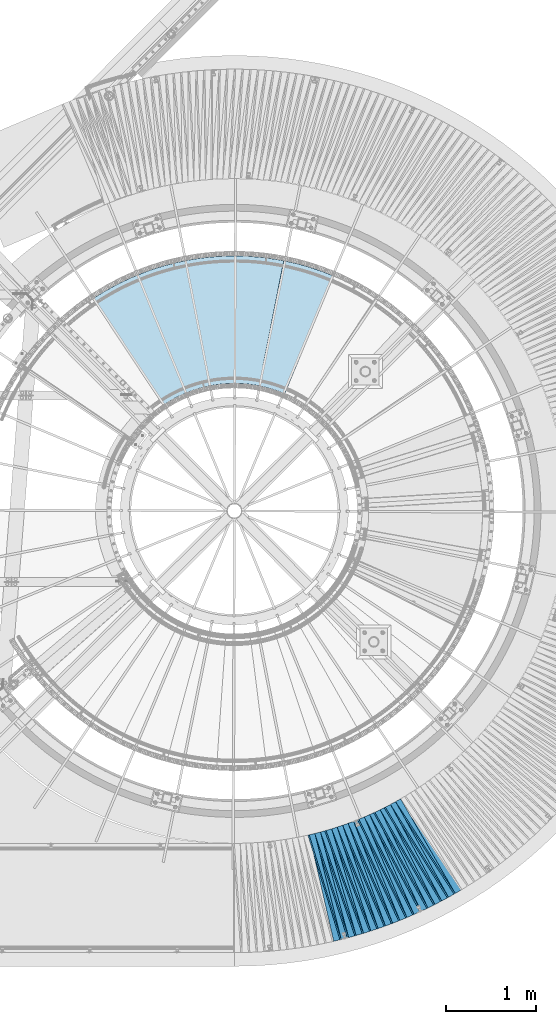
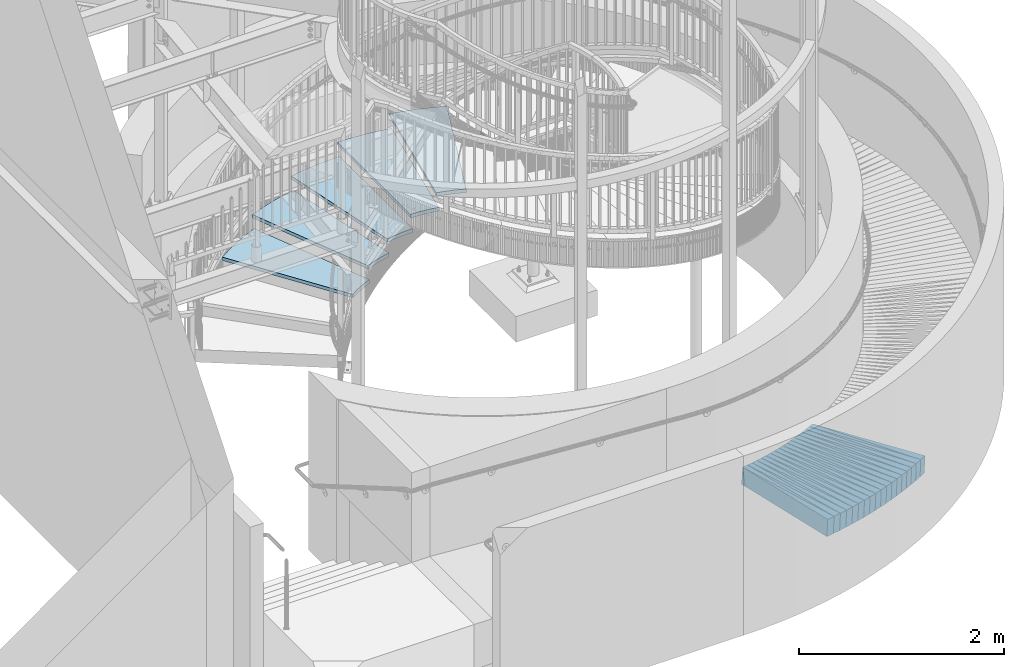
# One storey, part 831 of 975: 40 plates.
"""IFC2X3 building model written with IfcOpenShell, lengths in millimetres."""

from ifc_helpers import new_model, si_unit, frame, origin_with_axes, place, context, subcontext, project, spatial, faceted_brep, material, type_object, element, save


model = new_model("IFC2X3")

# Units and contexts
model_context = context("Model", 3, precision=1e-05, world=origin_with_axes())
body_context = subcontext(model_context, "Body", "Model", "MODEL_VIEW")
ifc_project = project(units=[si_unit("LENGTHUNIT", "METRE", prefix="MILLI"), si_unit("AREAUNIT", "SQUARE_METRE"), si_unit("VOLUMEUNIT", "CUBIC_METRE"), si_unit("MASSUNIT", "GRAM", prefix="KILO"), si_unit("TIMEUNIT", "SECOND"), si_unit("PLANEANGLEUNIT", "RADIAN"), si_unit("SOLIDANGLEUNIT", "STERADIAN"), si_unit("THERMODYNAMICTEMPERATUREUNIT", "DEGREE_CELSIUS"), si_unit("LUMINOUSINTENSITYUNIT", "LUMEN")], contexts=[model_context])

# Site, building, storey
site_placement = place(None, origin_with_axes())
site = spatial("IfcSite", under=ifc_project, at=site_placement, CompositionType="ELEMENT")
building_placement = place(site_placement, origin_with_axes())
building = spatial("IfcBuilding", under=site, at=building_placement, Name="Undefined", CompositionType="ELEMENT")
storey_placement = place(building_placement, origin_with_axes())
storey = spatial("IfcBuildingStorey", under=building, at=storey_placement, Name="Undefined", CompositionType="ELEMENT", Elevation=0.0)

# Plates
ifc_material_1 = material(Name="STEEL/A36")
plate_type_1 = type_object("IfcPlateType", PredefinedType="NOTDEFINED")
plate_1_placement = place(storey_placement, frame((35920.8964027804, -1378.14822666948, 716.361777581016), z_axis=(-0.954496786688784, -0.292778180238574, 0.0567170289857864), x_axis=(-0.293029846867584, 0.956094867567946, 0.00401410699818602)))
element("IfcPlate", 1, at=plate_1_placement, inside=storey, type_object=plate_type_1, material=ifc_material_1, Name="SLAB", context=body_context, shape_type="Brep", body=[
    faceted_brep([(-6.82121026329696e-12, -100.000000000011, -1.09139364212751e-10), (4.60088825229286, -99.9999999999914, 86.0681838990786), (4.60088825226376, 100.000000000007, 86.0681838989476), (5.91171556152403e-12, 100.000000000011, 1.09139364212751e-10), (1220.69482422005, -99.9999999997549, 2.71393219009042e-09), (1220.69482422003, 100.000000000243, 2.58296495303512e-09)], [[[0, 1, 2, 3]], [[1, 4, 5, 2]], [[4, 0, 3, 5]], [[5, 3, 2]], [[4, 1, 0]]]),
])
plate_2_placement = place(storey_placement, frame((36004.2019013048, -1357.47426056205, 711.368760540763), z_axis=(-0.949207461288295, -0.309272651850224, 0.0579277330141645), x_axis=(-0.309564529150049, 0.950869634460905, 0.00409152200198324)))
element("IfcPlate", 2, at=plate_2_placement, inside=storey, type_object=plate_type_1, material=ifc_material_1, Name="SLAB", context=body_context, shape_type="Brep", body=[
    faceted_brep([(-6.82121026329696e-12, -100.000000000011, -1.09139364212751e-10), (6.06005096435911, -99.9999999999932, 85.886413574226), (6.06005096422268, 99.9999999999754, 85.886413573855), (5.91171556152403e-12, 100.000000000011, 1.09139364212751e-10), (1222.03918456931, -100.000000000225, -4.35829861089587e-09), (1222.03918456917, 99.9999999997449, -4.72937244921923e-09)], [[[0, 1, 2, 3]], [[1, 4, 5, 2]], [[4, 0, 3, 5]], [[5, 3, 2]], [[4, 1, 0]]]),
])
plate_3_placement = place(storey_placement, frame((36086.9312302087, -1333.87117556093, 706.368520326886), z_axis=(-0.943633897037843, -0.325889980459857, 0.0578860000090426), x_axis=(-0.326210111022737, 0.945288414065887, 0.00409605900028552)))
element("IfcPlate", 3, at=plate_3_placement, inside=storey, type_object=plate_type_1, material=ifc_material_1, Name="SLAB", context=body_context, shape_type="Brep", body=[
    faceted_brep([(-6.82121026329696e-12, -100.000000000011, -1.09139364212751e-10), (4.59472084043227, -100.000000000002, 86.0515441893949), (4.59472084065237, 100.000000000032, 86.0515441899915), (5.91171556152403e-12, 100.000000000011, 1.09139364212751e-10), (1220.68566894547, -99.9999999999995, 5.23868948221207e-10), (1220.68566894569, 100.000000000035, 1.12049747258425e-09)], [[[0, 1, 2, 3]], [[1, 4, 5, 2]], [[4, 0, 3, 5]], [[5, 3, 2]], [[4, 1, 0]]]),
])
plate_4_placement = place(storey_placement, frame((36169.7703492344, -1310.23678120181, 701.46181464158), z_axis=(-0.937884665391323, -0.342278770379612, 0.0567238730273853), x_axis=(-0.342613996096858, 0.939467707265594, 0.00400957400113354)))
element("IfcPlate", 4, at=plate_4_placement, inside=storey, type_object=plate_type_1, material=ifc_material_1, Name="SLAB", context=body_context, shape_type="Brep", body=[
    faceted_brep([(-6.82121026329696e-12, -100.000000000011, -1.09139364212751e-10), (6.08843994146082, -99.9999999999945, 85.9530181886003), (6.08843994141171, 100.000000000001, 85.9530181885275), (5.91171556152403e-12, 100.000000000011, 1.09139364212751e-10), (1222.07495117056, -100.000000000141, -3.9945007301867e-09), (1222.07495117051, 99.9999999998536, -4.05998434871435e-09)], [[[0, 1, 2, 3]], [[1, 4, 5, 2]], [[4, 0, 3, 5]], [[5, 3, 2]], [[4, 1, 0]]]),
])
plate_5_placement = place(storey_placement, frame((36251.490931724, -1283.73453258542, 696.562272327894), z_axis=(-0.931754587337628, -0.358617748051485, 0.0568040470192745), x_axis=(-0.358981676959118, 0.933335974893702, 0.00401417199954286)))
element("IfcPlate", 5, at=plate_5_placement, inside=storey, type_object=plate_type_1, material=ifc_material_1, Name="SLAB", context=body_context, shape_type="Brep", body=[
    faceted_brep([(-6.82121026329696e-12, -100.000000000011, -1.09139364212751e-10), (4.52173566817692, -99.9999999999995, 85.9419250488136), (4.52173566800593, 99.9999999999791, 85.9419250483625), (5.91171556152403e-12, 100.000000000011, 1.09139364212751e-10), (1220.67517089887, -99.9999999999168, 9.45874489843845e-10), (1220.6751708987, 100.000000000062, 5.02041075378656e-10)], [[[0, 1, 2, 3]], [[1, 4, 5, 2]], [[4, 0, 3, 5]], [[5, 3, 2]], [[4, 1, 0]]]),
])
plate_6_placement = place(storey_placement, frame((36333.2156293288, -1257.36336816964, 691.568640229244), z_axis=(-0.925306523105922, -0.374772753904389, 0.0579070050041398), x_axis=(-0.375179573168435, 0.926943120416151, 0.00409138000183681)))
element("IfcPlate", 6, at=plate_6_placement, inside=storey, type_object=plate_type_1, material=ifc_material_1, Name="SLAB", context=body_context, shape_type="Brep", body=[
    faceted_brep([(-6.82121026329696e-12, -100.000000000011, -1.09139364212751e-10), (6.14615344981939, -100.000000000034, 85.9110870356817), (6.14615344995764, 99.9999999999955, 85.91108703598), (5.91171556152403e-12, 100.000000000011, 1.09139364212751e-10), (1222.0814208972, -100.000000000133, -3.37604433298111e-09), (1222.08142089734, 99.9999999998968, -3.07045411318541e-09)], [[[0, 1, 2, 3]], [[1, 4, 5, 2]], [[4, 0, 3, 5]], [[5, 3, 2]], [[4, 1, 0]]]),
])
plate_7_placement = place(storey_placement, frame((36414.1526938858, -1228.05746409633, 686.568332578839), z_axis=(-0.918592129707638, -0.390949428711251, 0.057853637997392), x_axis=(-0.391383650858655, 0.920218486667674, 0.00409568499852085)))
element("IfcPlate", 7, at=plate_7_placement, inside=storey, type_object=plate_type_1, material=ifc_material_1, Name="SLAB", context=body_context, shape_type="Brep", body=[
    faceted_brep([(-6.82121026329696e-12, -100.000000000011, -1.09139364212751e-10), (4.62899208068302, -99.9999999999941, 86.0972824096752), (4.628992080854, 100.000000000022, 86.0972824100827), (5.91171556152403e-12, 100.000000000011, 1.09139364212751e-10), (1220.79699706996, -100.000000000087, -1.06228981167078e-09), (1220.79699707013, 99.9999999999295, -6.54836185276508e-10)], [[[0, 1, 2, 3]], [[1, 4, 5, 2]], [[4, 0, 3, 5]], [[5, 3, 2]], [[4, 1, 0]]]),
])
plate_8_placement = place(storey_placement, frame((36494.983607962, -1198.65429520142, 681.568517486554), z_axis=(-0.911649744234688, -0.406870953763068, 0.0578858430081083), x_axis=(-0.407334282004116, 0.913269973009231, 0.00409134500004132)))
element("IfcPlate", 8, at=plate_8_placement, inside=storey, type_object=plate_type_1, material=ifc_material_1, Name="SLAB", context=body_context, shape_type="Brep", body=[
    faceted_brep([(-6.82121026329696e-12, -100.000000000011, -1.09139364212751e-10), (5.99160242081416, -99.9999999999941, 85.9534225464049), (5.99160242099242, 100.000000000025, 85.9534225467796), (5.91171556152403e-12, 100.000000000011, 1.09139364212751e-10), (1222.09204101577, -99.9999999999236, 2.08456185646355e-09), (1222.09204101595, 100.000000000095, 2.45563569478691e-09)], [[[0, 1, 2, 3]], [[1, 4, 5, 2]], [[4, 0, 3, 5]], [[5, 3, 2]], [[4, 1, 0]]]),
])
plate_9_placement = place(storey_placement, frame((36574.7147083556, -1166.55107740228, 676.568794749534), z_axis=(-0.904383035620557, -0.422770688262338, 0.0579333239848624), x_axis=(-0.423263062090813, 0.905997574194386, 0.00409583000087882)))
element("IfcPlate", 9, at=plate_9_placement, inside=storey, type_object=plate_type_1, material=ifc_material_1, Name="SLAB", context=body_context, shape_type="Brep", body=[
    faceted_brep([(-6.82121026329696e-12, -100.000000000011, -1.09139364212751e-10), (4.58142328264876, -100.000000000006, 85.9822082519822), (4.58142328285248, 100.00000000003, 85.9822082524588), (5.91171556152403e-12, 100.000000000011, 1.09139364212751e-10), (1220.75378417907, -100.000000000089, -2.72848410531878e-10), (1220.75378417927, 99.9999999999472, 1.96450855582952e-10)], [[[0, 1, 2, 3]], [[1, 4, 5, 2]], [[4, 0, 3, 5]], [[5, 3, 2]], [[4, 1, 0]]]),
])
plate_10_placement = place(storey_placement, frame((36654.5599082367, -1134.40145698284, 671.662077887171), z_axis=(-0.896980232433394, -0.438410318483202, 0.0567701970332249), x_axis=(-0.438910128800131, 0.898522021590838, 0.00400943299817424)))
element("IfcPlate", 10, at=plate_10_placement, inside=storey, type_object=plate_type_1, material=ifc_material_1, Name="SLAB", context=body_context, shape_type="Brep", body=[
    faceted_brep([(-6.82121026329696e-12, -100.000000000011, -1.09139364212751e-10), (6.06837415692644, -99.999999999995, 85.8843078612772), (6.06837415714836, 100.000000000021, 85.8843078617319), (5.91171556152403e-12, 100.000000000011, 1.09139364212751e-10), (1222.1180419939, -99.9999999997649, 3.76167008653283e-09), (1222.11804199413, 100.000000000251, 4.22005541622639e-09)], [[[0, 1, 2, 3]], [[1, 4, 5, 2]], [[4, 0, 3, 5]], [[5, 3, 2]], [[4, 1, 0]]]),
])
plate_11_placement = place(storey_placement, frame((36733.1994987212, -1099.59200583341, 666.761968027348), z_axis=(-0.88918828648457, -0.454008330304203, 0.056750569979735), x_axis=(-0.45453432701405, 0.890720178027532, 0.00401372900012404)))
element("IfcPlate", 11, at=plate_11_placement, inside=storey, type_object=plate_type_1, material=ifc_material_1, Name="SLAB", context=body_context, shape_type="Brep", body=[
    faceted_brep([(-6.82121026329696e-12, -100.000000000011, -1.09139364212751e-10), (4.65993118271945, -100.000000000017, 86.0131683346881), (4.65993118298866, 100.000000000018, 86.0131683352229), (5.91171556152403e-12, 100.000000000011, 1.09139364212751e-10), (1220.80993652368, -99.9999999999736, 1.78260961547494e-10), (1220.80993652395, 100.000000000062, 7.13043846189976e-10)], [[[0, 1, 2, 3]], [[1, 4, 5, 2]], [[4, 0, 3, 5]], [[5, 3, 2]], [[4, 1, 0]]]),
])
plate_12_placement = place(storey_placement, frame((36811.7366505124, -1064.72884550045, 661.768424916436), z_axis=(-0.88107027688066, -0.469431831245268, 0.0578698799994612), x_axis=(-0.470006602999539, 0.882653416999134, 0.00409128299999595)))
element("IfcPlate", 12, at=plate_12_placement, inside=storey, type_object=plate_type_1, material=ifc_material_1, Name="SLAB", context=body_context, shape_type="Brep", body=[
    faceted_brep([(-6.82121026329696e-12, -100.000000000011, -1.09139364212751e-10), (6.07010602975788, -99.9999999999704, 85.9715881351913), (6.070106029405, 99.9999999999905, 85.9715881345655), (5.91171556152403e-12, 100.000000000011, 1.09139364212751e-10), (1222.11047363219, -100.000000000048, -1.97906047105789e-09), (1222.11047363184, 99.9999999999127, -2.60479282587767e-09)], [[[0, 1, 2, 3]], [[1, 4, 5, 2]], [[4, 0, 3, 5]], [[5, 3, 2]], [[4, 1, 0]]]),
])
plate_13_placement = place(storey_placement, frame((36889.0751816554, -1027.07634903161, 656.862300750628), z_axis=(-0.87278913368896, -0.484780217258035, 0.0568090579901409), x_axis=(-0.485360783977436, 0.874304750959353, 0.00401395399981338)))
element("IfcPlate", 13, at=plate_13_placement, inside=storey, type_object=plate_type_1, material=ifc_material_1, Name="SLAB", context=body_context, shape_type="Brep", body=[
    faceted_brep([(-6.82121026329696e-12, -100.000000000011, -1.09139364212751e-10), (4.52823162078494, -99.9999999999968, 85.9338989257849), (4.52823162080676, 100.000000000007, 85.9338989258285), (5.91171556152403e-12, 100.000000000011, 1.09139364212751e-10), (1220.7413330068, -100.000000000063, -2.75758793577552e-09), (1220.74133300682, 99.9999999999404, -2.71757016889751e-09)], [[[0, 1, 2, 3]], [[1, 4, 5, 2]], [[4, 0, 3, 5]], [[5, 3, 2]], [[4, 1, 0]]]),
])
plate_14_placement = place(storey_placement, frame((36966.3198758771, -989.513249423396, 651.868569825225), z_axis=(-0.864184059545956, -0.499834068529714, 0.0578948630165455), x_axis=(-0.500464260914906, 0.865747528852798, 0.00409143399930438)))
element("IfcPlate", 14, at=plate_14_placement, inside=storey, type_object=plate_type_1, material=ifc_material_1, Name="SLAB", context=body_context, shape_type="Brep", body=[
    faceted_brep([(-6.82121026329696e-12, -100.000000000011, -1.09139364212751e-10), (6.06766271590095, -100.00000000001, 85.9346466064417), (6.06766271579909, 99.9999999999886, 85.9346466062489), (5.91171556152403e-12, 100.000000000011, 1.09139364212751e-10), (1222.06530761599, -100.000000000115, -2.53930920735002e-09), (1222.06530761589, 99.9999999998831, -2.72848410531878e-09)], [[[0, 1, 2, 3]], [[1, 4, 5, 2]], [[4, 0, 3, 5]], [[5, 3, 2]], [[4, 1, 0]]]),
])
plate_15_placement = place(storey_placement, frame((37042.3662291072, -949.152657284375, 646.962041510433), z_axis=(-0.855342711595652, -0.514943445694854, 0.056763486997444), x_axis=(-0.515575374060596, 0.856834828100706, 0.00401385300047175)))
element("IfcPlate", 15, at=plate_15_placement, inside=storey, type_object=plate_type_1, material=ifc_material_1, Name="SLAB", context=body_context, shape_type="Brep", body=[
    faceted_brep([(-6.82121026329696e-12, -100.000000000011, -1.09139364212751e-10), (4.53571176556943, -99.9999999999645, 86.0023651127594), (4.5357117652602, 99.9999999999968, 86.0023651122647), (5.91171556152403e-12, 100.000000000011, 1.09139364212751e-10), (1220.77209472747, -99.9999999999523, 1.20780896395445e-09), (1220.77209472717, 100.000000000009, 7.13043846189976e-10)], [[[0, 1, 2, 3]], [[1, 4, 5, 2]], [[4, 0, 3, 5]], [[5, 3, 2]], [[4, 1, 0]]]),
])
plate_16_placement = place(storey_placement, frame((37118.3157841667, -908.891558633209, 641.968306990989), z_axis=(-0.846195501974491, -0.529723139632555, 0.0578495270159394), x_axis=(-0.530406338074301, 0.847733671118757, 0.00409137900057319)))
element("IfcPlate", 16, at=plate_16_placement, inside=storey, type_object=plate_type_1, material=ifc_material_1, Name="SLAB", context=body_context, shape_type="Brep", body=[
    faceted_brep([(-6.82121026329696e-12, -100.000000000011, -1.09139364212751e-10), (6.08289813996817, -100.000000000001, 86.0009231567601), (6.08289813989177, 99.9999999999964, 86.0009231566473), (5.91171556152403e-12, 100.000000000011, 1.09139364212751e-10), (1222.08190918039, -99.9999999999072, 2.24827090278268e-09), (1222.08190918031, 100.000000000091, 2.13549355976284e-09)], [[[0, 1, 2, 3]], [[1, 4, 5, 2]], [[4, 0, 3, 5]], [[5, 3, 2]], [[4, 1, 0]]]),
])
plate_17_placement = place(storey_placement, frame((37192.8606229598, -865.983252642477, 636.968559452032), z_axis=(-0.836737998058605, -0.54453461889583, 0.0578927580000438), x_axis=(-0.545245774854708, 0.838266227776631, 0.00409589699890857)))
element("IfcPlate", 17, at=plate_17_placement, inside=storey, type_object=plate_type_1, material=ifc_material_1, Name="SLAB", context=body_context, shape_type="Brep", body=[
    faceted_brep([(-6.82121026329696e-12, -100.000000000011, -1.09139364212751e-10), (4.5958418844275, -100.000000000027, 86.0414352414045), (4.59584188450026, 99.9999999999909, 86.0414352415391), (5.91171556152403e-12, 100.000000000011, 1.09139364212751e-10), (1220.73388671846, -100.000000000067, 1.43700162880123e-09), (1220.73388671853, 99.9999999999504, 1.56433088704944e-09)], [[[0, 1, 2, 3]], [[1, 4, 5, 2]], [[4, 0, 3, 5]], [[5, 3, 2]], [[4, 1, 0]]]),
])
plate_18_placement = place(storey_placement, frame((37267.4111523157, -823.070803538224, 631.96850915271), z_axis=(-0.827164374865569, -0.558970923490801, 0.0578843989784338), x_axis=(-0.559708469972532, 0.828679484959334, 0.00409143599979922)))
element("IfcPlate", 18, at=plate_18_placement, inside=storey, type_object=plate_type_1, material=ifc_material_1, Name="SLAB", context=body_context, shape_type="Brep", body=[
    faceted_brep([(-6.82121026329696e-12, -100.000000000011, -1.09139364212751e-10), (6.08552026765392, -99.9999999999841, 85.9489212038679), (6.08552026739926, 99.9999999999905, 85.9489212034969), (5.91171556152403e-12, 100.000000000011, 1.09139364212751e-10), (1222.06481933391, -100.000000000233, -4.74756234325469e-09), (1222.06481933366, 99.9999999997408, -5.12227416038513e-09)], [[[0, 1, 2, 3]], [[1, 4, 5, 2]], [[4, 0, 3, 5]], [[5, 3, 2]], [[4, 1, 0]]]),
])
plate_type_2 = type_object("IfcPlateType", PredefinedType="NOTDEFINED")
plate_19_placement = place(storey_placement, frame((35919.1128220705, -1378.69538794248, 716.485267739358), z_axis=(-0.96752877665984, -0.241227795294288, 0.0754799119804052), x_axis=(-0.241917909055923, 0.970296720224288, 0.0)))
element("IfcPlate", 19, at=plate_19_placement, inside=storey, type_object=plate_type_2, material=ifc_material_1, Name="SLAB", context=body_context, shape_type="Brep", body=[
    faceted_brep([(-6.82121026329696e-12, -100.000000000011, -1.09139364212751e-10), (1218.96728515676, -99.9999999998372, 64.9179382345392), (1218.9672851566, 100.000000000106, 64.9179382339062), (5.91171556152403e-12, 100.000000000011, 1.09139364212751e-10), (1219.0085449224, -99.9999999998281, 1.32422428578138e-09), (1219.00854492224, 100.000000000115, 6.83940015733242e-10)], [[[0, 1, 2, 3]], [[1, 4, 5, 2]], [[4, 0, 3, 5]], [[5, 3, 2]], [[4, 1, 0]]]),
])
plate_20_placement = place(storey_placement, frame((36002.3938376574, -1358.06344572857, 711.497297679678), z_axis=(-0.963061709338831, -0.258021373084371, 0.0770526770269812), x_axis=(-0.258790751989735, 0.965933406961674, 0.0)))
element("IfcPlate", 20, at=plate_20_placement, inside=storey, type_object=plate_type_2, material=ifc_material_1, Name="SLAB", context=body_context, shape_type="Brep", body=[
    faceted_brep([(-6.82121026329696e-12, -100.000000000011, -1.09139364212751e-10), (1220.3151855476, -99.9999999998158, 64.8906707786373), (1220.31518554762, 100.000000000179, 64.8906707787028), (5.91171556152403e-12, 100.000000000011, 1.09139364212751e-10), (1219.13171386798, -99.9999999998022, 3.66708263754845e-09), (1219.13171386799, 100.000000000191, 3.72529029846191e-09)], [[[0, 1, 2, 3]], [[1, 4, 5, 2]], [[4, 0, 3, 5]], [[5, 3, 2]], [[4, 1, 0]]]),
])
plate_21_placement = place(storey_placement, frame((36085.1328502206, -1334.49233647649, 706.497054161413), z_axis=(-0.958408014308282, -0.274812334180605, 0.0770211600267379), x_axis=(-0.27563110785402, 0.961263487490899, 0.0)))
element("IfcPlate", 21, at=plate_21_placement, inside=storey, type_object=plate_type_2, material=ifc_material_1, Name="SLAB", context=body_context, shape_type="Brep", body=[
    faceted_brep([(-6.82121026329696e-12, -100.000000000011, -1.09139364212751e-10), (1218.95825195375, -99.9999999998345, 64.9172287008769), (1218.95825195363, 100.000000000131, 64.9172287004985), (5.91171556152403e-12, 100.000000000011, 1.09139364212751e-10), (1219.02062988339, -99.9999999998413, 1.29512045532465e-09), (1219.02062988328, 100.000000000125, 9.24046617001295e-10)], [[[0, 1, 2, 3]], [[1, 4, 5, 2]], [[4, 0, 3, 5]], [[5, 3, 2]], [[4, 1, 0]]]),
])
plate_22_placement = place(storey_placement, frame((36168.0133674261, -1310.87806262466, 701.585675536121), z_axis=(-0.953561713120321, -0.291572820429493, 0.0755337650182294), x_axis=(-0.292408159003422, 0.956293610011188, 0.0)))
element("IfcPlate", 22, at=plate_22_placement, inside=storey, type_object=plate_type_2, material=ifc_material_1, Name="SLAB", context=body_context, shape_type="Brep", body=[
    faceted_brep([(-6.82121026329696e-12, -100.000000000011, -1.09139364212751e-10), (1220.35205078102, -100.000000000074, 64.8716506948113), (1220.352050781, 99.99999999992, 64.8716506947821), (5.91171556152403e-12, 100.000000000011, 1.09139364212751e-10), (1219.18627929667, -100.000000000066, 4.07453626394272e-10), (1219.18627929667, 99.9999999999281, 3.85625753551722e-10)], [[[0, 1, 2, 3]], [[1, 4, 5, 2]], [[4, 0, 3, 5]], [[5, 3, 2]], [[4, 1, 0]]]),
])
plate_23_placement = place(storey_placement, frame((36249.7511942118, -1284.40420549324, 696.68581640979), z_axis=(-0.948333289081256, -0.308149012195692, 0.0755523600104376), x_axis=(-0.309032277156803, 0.95105155048256, 0.0)))
element("IfcPlate", 23, at=plate_23_placement, inside=storey, type_object=plate_type_2, material=ifc_material_1, Name="SLAB", context=body_context, shape_type="Brep", body=[
    faceted_brep([(-6.82121026329696e-12, -100.000000000011, -1.09139364212751e-10), (1218.95092773572, -99.999999999699, 64.8556823770195), (1218.95092773585, 100.000000000338, 64.8556823774634), (5.91171556152403e-12, 100.000000000011, 1.09139364212751e-10), (1218.96655273571, -99.9999999997003, 4.27826307713985e-09), (1218.96655273585, 100.000000000337, 4.72209649160504e-09)], [[[0, 1, 2, 3]], [[1, 4, 5, 2]], [[4, 0, 3, 5]], [[5, 3, 2]], [[4, 1, 0]]]),
])
plate_24_placement = place(storey_placement, frame((36331.4575008463, -1258.07553498233, 691.69677146439), z_axis=(-0.942722834778449, -0.324572079469987, 0.0769845569956387), x_axis=(-0.325538183915045, 0.945528894753246, 0.0)))
element("IfcPlate", 24, at=plate_24_placement, inside=storey, type_object=plate_type_2, material=ifc_material_1, Name="SLAB", context=body_context, shape_type="Brep", body=[
    faceted_brep([(-6.82121026329696e-12, -100.000000000011, -1.09139364212751e-10), (1220.35437011606, -100.00000000028, 64.9480895959568), (1220.35437011587, 99.9999999996735, 64.948089595382), (5.91171556152403e-12, 100.000000000011, 1.09139364212751e-10), (1219.21179199108, -100.000000000276, -3.688910510391e-09), (1219.21179199089, 99.9999999996767, -4.27098711952567e-09)], [[[0, 1, 2, 3]], [[1, 4, 5, 2]], [[4, 0, 3, 5]], [[5, 3, 2]], [[4, 1, 0]]]),
])
plate_25_placement = place(storey_placement, frame((36412.3992612795, -1228.803799886, 686.69703794567), z_axis=(-0.936891993262727, -0.341029994571751, 0.0770190610341785), x_axis=(-0.342046000986895, 0.939683208963996, 0.0)))
element("IfcPlate", 25, at=plate_25_placement, inside=storey, type_object=plate_type_2, material=ifc_material_1, Name="SLAB", context=body_context, shape_type="Brep", body=[
    faceted_brep([(-6.82121026329696e-12, -100.000000000011, -1.09139364212751e-10), (1219.06970214866, -99.9999999999459, 64.9189910895802), (1219.06970214853, 100.000000000023, 64.9189910891946), (5.91171556152403e-12, 100.000000000011, 1.09139364212751e-10), (1219.13427734402, -99.9999999999332, 0.0), (1219.1342773439, 100.000000000036, -4.00177668780088e-10)], [[[0, 1, 2, 3]], [[1, 4, 5, 2]], [[4, 0, 3, 5]], [[5, 3, 2]], [[4, 1, 0]]]),
])
plate_26_placement = place(storey_placement, frame((36493.2415159557, -1199.43187610233, 681.697446031913), z_axis=(-0.930780009613574, -0.357363261133601, 0.0770718709758147), x_axis=(-0.358429395159591, 0.93355683741566, 0.0)))
element("IfcPlate", 26, at=plate_26_placement, inside=storey, type_object=plate_type_2, material=ifc_material_1, Name="SLAB", context=body_context, shape_type="Brep", body=[
    faceted_brep([(-6.82121026329696e-12, -100.000000000011, -1.09139364212751e-10), (1220.36889648319, -100.000000000226, 64.8745117158251), (1220.36889648332, 99.9999999998022, 64.8745117162034), (5.91171556152403e-12, 100.000000000011, 1.09139364212751e-10), (1219.20800781131, -100.000000000226, -3.93629306927323e-09), (1219.20800781144, 99.9999999998022, -3.5579432733357e-09)], [[[0, 1, 2, 3]], [[1, 4, 5, 2]], [[4, 0, 3, 5]], [[5, 3, 2]], [[4, 1, 0]]]),
])
plate_27_placement = place(storey_placement, frame((36572.9964508113, -1167.3543907226, 676.696966573689), z_axis=(-0.924422145806492, -0.373514636681912, 0.077009820976938), x_axis=(-0.374627154099484, 0.927175547246217, 0.0)))
element("IfcPlate", 27, at=plate_27_placement, inside=storey, type_object=plate_type_2, material=ifc_material_1, Name="SLAB", context=body_context, shape_type="Brep", body=[
    faceted_brep([(-6.82121026329696e-12, -100.000000000011, -1.09139364212751e-10), (1219.02600097766, -99.9999999997844, 64.9267807035139), (1219.02600097787, 100.000000000256, 64.9267807040087), (5.91171556152403e-12, 100.000000000011, 1.09139364212751e-10), (1219.07873535266, -99.9999999997826, 3.84170562028885e-09), (1219.07873535286, 100.000000000259, 4.34374669566751e-09)], [[[0, 1, 2, 3]], [[1, 4, 5, 2]], [[4, 0, 3, 5]], [[5, 3, 2]], [[4, 1, 0]]]),
])
plate_28_placement = place(storey_placement, frame((36652.8932932415, -1135.2161131751, 671.784869987444), z_axis=(-0.91790852157437, -0.389557006536563, 0.0754273470262995), x_axis=(-0.390669907858242, 0.920530837665981, 0.0)))
element("IfcPlate", 28, at=plate_28_placement, inside=storey, type_object=plate_type_2, material=ifc_material_1, Name="SLAB", context=body_context, shape_type="Brep", body=[
    faceted_brep([(-6.82121026329696e-12, -100.000000000011, -1.09139364212751e-10), (1220.39025878891, -100.000000000051, 64.963172911921), (1220.39025878912, 99.9999999999777, 64.9631729123503), (5.91171556152403e-12, 100.000000000011, 1.09139364212751e-10), (1219.18786621082, -100.000000000042, 8.44011083245277e-10), (1219.18786621103, 99.9999999999868, 1.28056854009628e-09)], [[[0, 1, 2, 3]], [[1, 4, 5, 2]], [[4, 0, 3, 5]], [[5, 3, 2]], [[4, 1, 0]]]),
])
plate_29_placement = place(storey_placement, frame((36731.5362891585, -1100.44129872796, 666.885663374038), z_axis=(-0.91095134926705, -0.405539803311627, 0.07553216002808), x_axis=(-0.406701600841965, 0.913561058645005, 0.0)))
element("IfcPlate", 29, at=plate_29_placement, inside=storey, type_object=plate_type_2, material=ifc_material_1, Name="SLAB", context=body_context, shape_type="Brep", body=[
    faceted_brep([(-6.82121026329696e-12, -100.000000000011, -1.09139364212751e-10), (1219.08496093714, -100.000000000055, 64.8730316155343), (1219.08496093694, 99.9999999999195, 64.8730316150468), (5.91171556152403e-12, 100.000000000011, 1.09139364212751e-10), (1219.07556152312, -100.000000000051, -1.36788003146648e-09), (1219.07556152292, 99.9999999999222, -1.86264514923096e-09)], [[[0, 1, 2, 3]], [[1, 4, 5, 2]], [[4, 0, 3, 5]], [[5, 3, 2]], [[4, 1, 0]]]),
])
plate_30_placement = place(storey_placement, frame((36810.0511813404, -1065.62694393139, 661.89748193056), z_axis=(-0.903602276664955, -0.421381224601891, 0.0770765149635185), x_axis=(-0.422638497785083, 0.906298350539141, 0.0)))
element("IfcPlate", 30, at=plate_30_placement, inside=storey, type_object=plate_type_2, material=ifc_material_1, Name="SLAB", context=body_context, shape_type="Brep", body=[
    faceted_brep([(-6.82121026329696e-12, -100.000000000011, -1.09139364212751e-10), (1220.38757324396, -99.9999999997117, 64.8706054725117), (1220.38757324383, 100.000000000268, 64.8706054722534), (5.91171556152403e-12, 100.000000000011, 1.09139364212751e-10), (1219.24523925953, -99.9999999997171, 4.74756234325469e-09), (1219.2452392594, 100.000000000261, 4.48926584795117e-09)], [[[0, 1, 2, 3]], [[1, 4, 5, 2]], [[4, 0, 3, 5]], [[5, 3, 2]], [[4, 1, 0]]]),
])
plate_31_placement = place(storey_placement, frame((36887.4550511525, -1027.97631034439, 656.985032619604), z_axis=(-0.896267186960723, -0.437049884469302, 0.0754488440128929), x_axis=(-0.438299180110717, 0.89882914322705, 0.0)))
element("IfcPlate", 31, at=plate_31_placement, inside=storey, type_object=plate_type_2, material=ifc_material_1, Name="SLAB", context=body_context, shape_type="Brep", body=[
    faceted_brep([(-6.82121026329696e-12, -100.000000000011, -1.09139364212751e-10), (1219.01257324197, -100.000000000018, 64.944664001232), (1219.01257324175, 99.9999999999568, 64.9446640008064), (5.91171556152403e-12, 100.000000000011, 1.09139364212751e-10), (1219.03039550764, -100.000000000016, 1.30239641293883e-09), (1219.03039550741, 99.9999999999586, 8.73114913702011e-10)], [[[0, 1, 2, 3]], [[1, 4, 5, 2]], [[4, 0, 3, 5]], [[5, 3, 2]], [[4, 1, 0]]]),
])
plate_32_placement = place(storey_placement, frame((36964.6671501218, -990.469253583193, 651.997635639847), z_axis=(-0.88837059605623, -0.452607810293325, 0.0770963950141708), x_axis=(-0.453958953936127, 0.891022596874634, 0.0)))
element("IfcPlate", 32, at=plate_32_placement, inside=storey, type_object=plate_type_2, material=ifc_material_1, Name="SLAB", context=body_context, shape_type="Brep", body=[
    faceted_brep([(-6.82121026329696e-12, -100.000000000011, -1.09139364212751e-10), (1220.34326171798, -100.000000000129, 64.8538742049095), (1220.34326171769, 99.9999999998263, 64.8538742043493), (5.91171556152403e-12, 100.000000000011, 1.09139364212751e-10), (1219.27319335866, -100.000000000116, -2.08456185646355e-09), (1219.27319335837, 99.999999999839, -2.63753463514149e-09)], [[[0, 1, 2, 3]], [[1, 4, 5, 2]], [[4, 0, 3, 5]], [[5, 3, 2]], [[4, 1, 0]]]),
])
plate_33_placement = place(storey_placement, frame((37040.7762739127, -950.109941917884, 647.0848837936), z_axis=(-0.880476982186012, -0.468049915981439, 0.0754291720117656), x_axis=(-0.469387123825513, 0.882992484671762, 0.0)))
element("IfcPlate", 33, at=plate_33_placement, inside=storey, type_object=plate_type_2, material=ifc_material_1, Name="SLAB", context=body_context, shape_type="Brep", body=[
    faceted_brep([(-6.82121026329696e-12, -100.000000000011, -1.09139364212751e-10), (1219.04235839912, -99.9999999999022, 64.9616012587285), (1219.04235839931, 100.000000000134, 64.9616012590632), (5.91171556152403e-12, 100.000000000011, 1.09139364212751e-10), (1219.03637695377, -99.999999999905, 7.27595761418343e-10), (1219.03637695396, 100.000000000131, 1.06228981167078e-09)], [[[0, 1, 2, 3]], [[1, 4, 5, 2]], [[4, 0, 3, 5]], [[5, 3, 2]], [[4, 1, 0]]]),
])
plate_34_placement = place(storey_placement, frame((37116.6905693507, -909.909041528424, 642.097914125784), z_axis=(-0.872000131000327, -0.483390488372731, 0.0771324010140024), x_axis=(-0.48483487997984, 0.874605704963633, 0.0)))
element("IfcPlate", 34, at=plate_34_placement, inside=storey, type_object=plate_type_2, material=ifc_material_1, Name="SLAB", context=body_context, shape_type="Brep", body=[
    faceted_brep([(-6.82121026329696e-12, -100.000000000011, -1.09139364212751e-10), (1220.36145019449, -100.000000000109, 64.8236007675514), (1220.36145019479, 99.9999999999236, 64.823600768068), (5.91171556152403e-12, 100.000000000011, 1.09139364212751e-10), (1219.17797851483, -100.000000000108, -2.062733983621e-09), (1219.17797851513, 99.9999999999245, -1.54250301420689e-09)], [[[0, 1, 2, 3]], [[1, 4, 5, 2]], [[4, 0, 3, 5]], [[5, 3, 2]], [[4, 1, 0]]]),
])
plate_35_placement = place(storey_placement, frame((37191.2724654143, -867.016886390764, 637.096509913477), z_axis=(-0.863460626505111, -0.498512126163824, 0.0769506760400832), x_axis=(-0.499994659918995, 0.866028486859693, 0.0)))
element("IfcPlate", 35, at=plate_35_placement, inside=storey, type_object=plate_type_2, material=ifc_material_1, Name="SLAB", context=body_context, shape_type="Brep", body=[
    faceted_brep([(-6.82121026329696e-12, -100.000000000011, -1.09139364212751e-10), (1219.0034179694, -99.9999999999186, 64.9766845714075), (1219.00341796934, 100.000000000085, 64.9766845713129), (5.91171556152403e-12, 100.000000000011, 1.09139364212751e-10), (1219.01306152413, -99.9999999999177, 1.88083504326642e-09), (1219.01306152406, 100.000000000086, 1.78988557308912e-09)], [[[0, 1, 2, 3]], [[1, 4, 5, 2]], [[4, 0, 3, 5]], [[5, 3, 2]], [[4, 1, 0]]]),
])
ifc_material_2 = material(Name="STEEL/Zero_Density")
plate_type_3 = type_object("IfcPlateType", PredefinedType="NOTDEFINED")
for number, where, z_axis, x_axis, name in (
    (36, (33949.5545843169, 4589.8716999953, 511.175), (-0.506488636078385, 0.862246636133454, 0.0), (0.862246636133456, 0.506488636078382, 0.0), "CONC."),
    (37, (34194.0916115511, 4719.40341446043, 688.975), (-0.329957917147498, 0.943995642421979, 0.0), (0.943995642421979, 0.329957917147499, 0.0), "CONC."),
    (38, (35009.9068251774, 4799.13965635423, 1222.375), (0.245743538008508, 0.969334882033583, 0.0), (0.969334882033583, -0.24574353800851, 0.0), "CONC."),
    (39, (34734.4937603568, 4826.05557110676, 1044.575), (0.053412690022873, 0.998572523427578, 0.0), (0.998572523427578, -0.0534126900228701, 0.0), "CONC."),
    (40, (34459.0809316818, 4799.13724014027, 866.775), (-0.140939614053175, 0.990018194373488, 0.0), (0.990018194373489, 0.140939614053173, 0.0), "CONC."),
):
    element("IfcPlate", number, at=place(storey_placement, frame(where, z_axis=z_axis, x_axis=x_axis)), inside=storey, type_object=plate_type_3, material=ifc_material_2, Name=name, context=body_context, shape_type="Brep", body=[
        faceted_brep([(226.607026755963, -22.2249999999999, -5.9806827134089), (151.21244687953, -22.2249999999999, 0.0171956564081484), (151.21244687953, 22.2249999999999, 0.0171956564081484), (226.607026755963, 22.2249999999999, -5.9806827134089), (75.6059955448145, -22.2249999999999, 2.01262449634305), (75.6059955448145, 22.2249999999999, 2.01262449634305), (0.0, -22.2249999999999, 0.0), (6.3512526843333, 22.2249999999999, 0.169069749597838), (-75.9923477177144, -22.2249999999999, 1420.59179687598), (-69.6411756631605, 22.2249999999999, 1420.76237488879), (75.2887648406067, -22.2249999999999, 1424.6548629265), (75.2887648406067, 22.2249999999999, 1424.6548629265), (226.570657118533, -22.2249999999999, 1420.62093290526), (226.570657118533, 22.2249999999999, 1420.62093290526), (377.420264969449, -22.2249999999999, 1408.50155446305), (377.420264969449, 22.2249999999999, 1408.50155446305), (501.974970329931, -22.2249999999999, 1391.75136796272), (501.974970329931, 22.2249999999999, 1391.75136796272), (301.578002929167, 22.2249999999999, -15.9641666403222), (301.578002929167, -22.2249999999999, -15.9641666403222)], [[[0, 1, 2, 3]], [[1, 4, 5, 2]], [[5, 4, 6, 7]], [[8, 9, 7, 6]], [[10, 11, 9, 8]], [[10, 12, 13, 11]], [[12, 14, 15, 13]], [[15, 14, 16, 17]], [[3, 2, 5, 7, 9, 11, 13, 15, 17, 18]], [[0, 3, 18, 19]], [[14, 12, 10, 8, 6, 4, 1, 0, 19, 16]], [[18, 17, 16, 19]]]),
    ])

save(model, "model.ifc")
